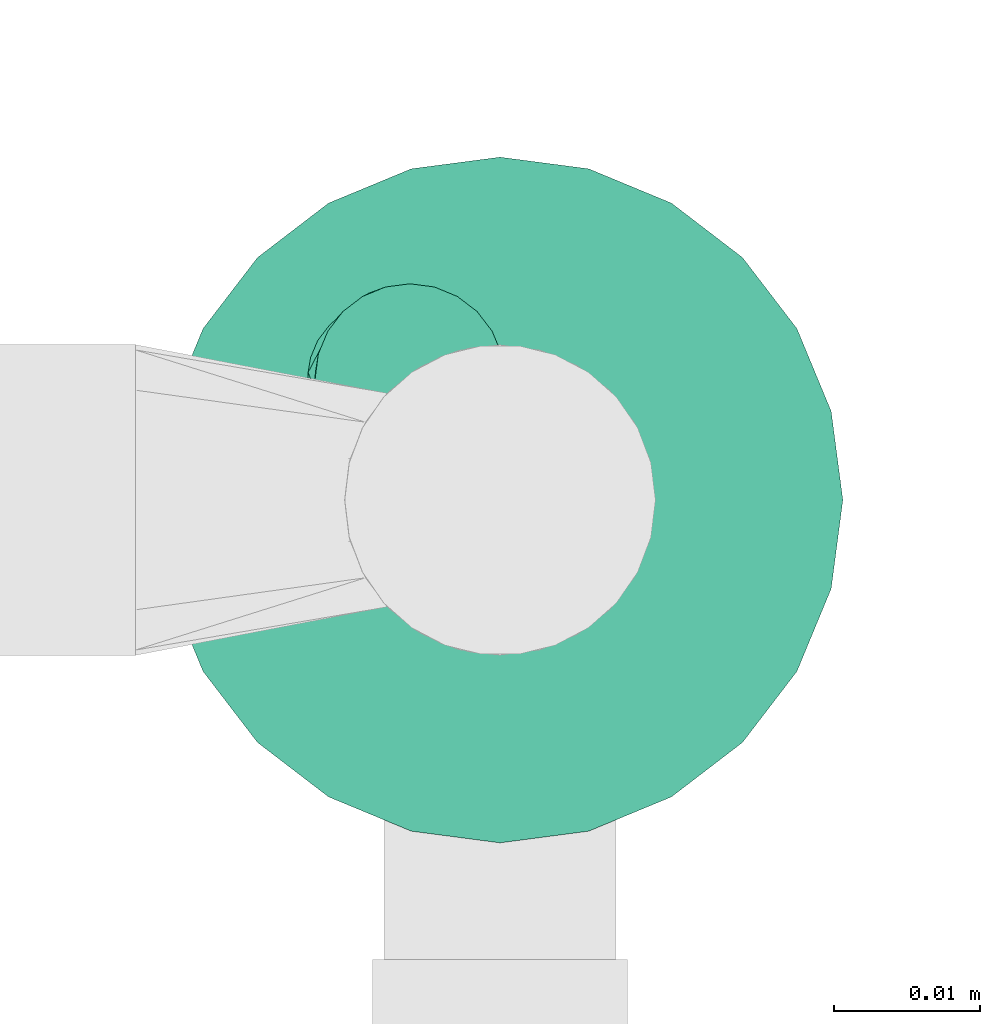
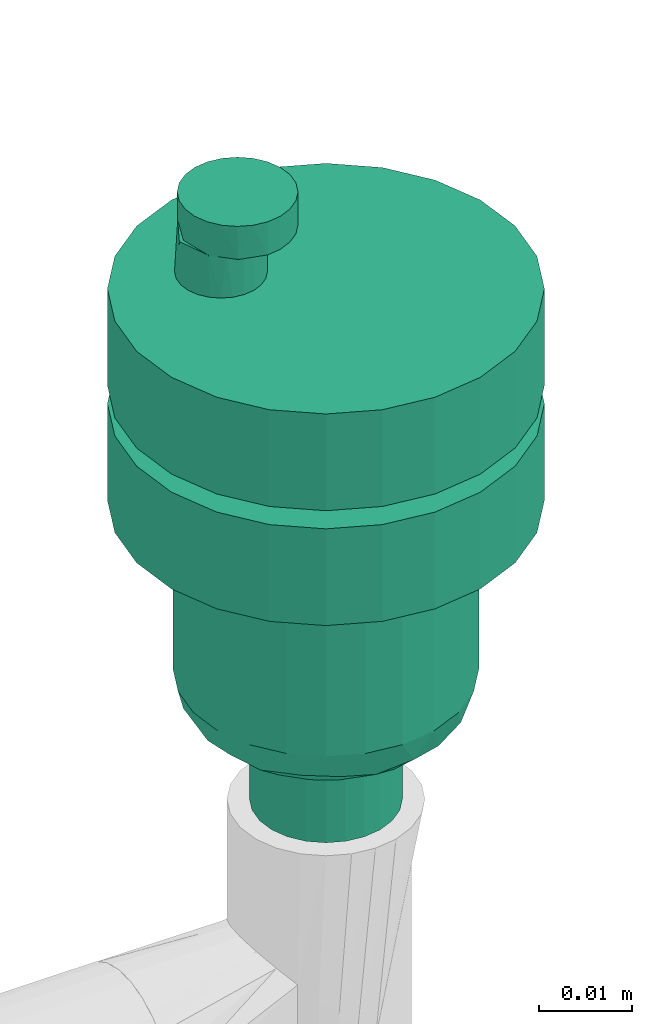
# One storey, part 791 of 827: 1 flow controller.
"""IFC2X3 building model written with IfcOpenShell, lengths in millimetres."""

from ifc_helpers import new_model, entity, si_unit, converted_unit, derived_unit, direction, frame, origin, place, context, subcontext, project, spatial, faceted_brep, source, transform, mapped, material, type_object, type_shapes, element, save


model = new_model("IFC2X3")

# Units and contexts
model_context = context("Model", 3, precision=0.01, world=origin(), true_north=direction((6.12303176911189e-17, 1.0)))
body_context = subcontext(model_context, "Body", "Model", "MODEL_VIEW")
ifc_project = project(units=[si_unit("LENGTHUNIT", "METRE", prefix="MILLI"), si_unit("AREAUNIT", "SQUARE_METRE"), si_unit("VOLUMEUNIT", "CUBIC_METRE"), converted_unit("PLANEANGLEUNIT", "DEGREE", entity("IfcRatioMeasure", 0.0174532925199433), si_unit("PLANEANGLEUNIT", "RADIAN"), dimensions=[0, 0, 0, 0, 0, 0, 0]), si_unit("MASSUNIT", "GRAM", prefix="KILO"), derived_unit("MASSDENSITYUNIT", [(si_unit("MASSUNIT", "GRAM", prefix="KILO"), 1), (si_unit("LENGTHUNIT", "METRE"), -3)]), derived_unit("MOMENTOFINERTIAUNIT", [(si_unit("LENGTHUNIT", "METRE"), 4)]), si_unit("TIMEUNIT", "SECOND"), si_unit("FREQUENCYUNIT", "HERTZ"), si_unit("THERMODYNAMICTEMPERATUREUNIT", "DEGREE_CELSIUS"), derived_unit("THERMALTRANSMITTANCEUNIT", [(si_unit("MASSUNIT", "GRAM", prefix="KILO"), 1), (si_unit("THERMODYNAMICTEMPERATUREUNIT", "KELVIN"), -1), (si_unit("TIMEUNIT", "SECOND"), -3)]), derived_unit("VOLUMETRICFLOWRATEUNIT", [(si_unit("LENGTHUNIT", "METRE"), 3), (si_unit("TIMEUNIT", "SECOND"), -1)]), derived_unit("MASSFLOWRATEUNIT", [(si_unit("MASSUNIT", "GRAM", prefix="KILO"), 1), (si_unit("TIMEUNIT", "SECOND"), -1)]), derived_unit("ROTATIONALFREQUENCYUNIT", [(si_unit("TIMEUNIT", "SECOND"), -1)]), si_unit("ELECTRICCURRENTUNIT", "AMPERE"), si_unit("ELECTRICVOLTAGEUNIT", "VOLT"), si_unit("POWERUNIT", "WATT"), si_unit("FORCEUNIT", "NEWTON", prefix="KILO"), si_unit("ILLUMINANCEUNIT", "LUX"), si_unit("LUMINOUSFLUXUNIT", "LUMEN"), si_unit("LUMINOUSINTENSITYUNIT", "CANDELA"), derived_unit("USERDEFINED", [(si_unit("MASSUNIT", "GRAM", prefix="KILO"), -1), (si_unit("LENGTHUNIT", "METRE"), -2), (si_unit("TIMEUNIT", "SECOND"), 3), (si_unit("LUMINOUSFLUXUNIT", "LUMEN"), 1)]), derived_unit("LINEARVELOCITYUNIT", [(si_unit("LENGTHUNIT", "METRE"), 1), (si_unit("TIMEUNIT", "SECOND"), -1)]), si_unit("PRESSUREUNIT", "PASCAL"), derived_unit("USERDEFINED", [(si_unit("LENGTHUNIT", "METRE"), -2), (si_unit("MASSUNIT", "GRAM", prefix="KILO"), 1), (si_unit("TIMEUNIT", "SECOND"), -2)]), derived_unit("LINEARFORCEUNIT", [(si_unit("MASSUNIT", "GRAM", prefix="KILO"), 1), (si_unit("LENGTHUNIT", "METRE"), 1), (si_unit("TIMEUNIT", "SECOND"), -2), (si_unit("LENGTHUNIT", "METRE"), -1)]), derived_unit("PLANARFORCEUNIT", [(si_unit("MASSUNIT", "GRAM", prefix="KILO"), 1), (si_unit("LENGTHUNIT", "METRE"), 1), (si_unit("TIMEUNIT", "SECOND"), -2), (si_unit("LENGTHUNIT", "METRE"), -2)])], contexts=[model_context])

# Site, building, storey
site_placement = place(None, origin())
site = spatial("IfcSite", under=ifc_project, at=site_placement, CompositionType="ELEMENT")
building_placement = place(site_placement, origin())
building = spatial("IfcBuilding", under=site, at=building_placement, CompositionType="ELEMENT")
storey_placement = place(building_placement, frame((0.0, 0.0, 28200.0)))
storey = spatial("IfcBuildingStorey", under=building, at=storey_placement, Name="08", CompositionType="ELEMENT", Elevation=28200.0)

# Flow controller
ifc_material = material()
valve_type = type_object("IfcValveType", PredefinedType="NOTDEFINED", material=ifc_material)
shared_shape = source(origin(), body_context, "Body", "Brep", [
    faceted_brep([(-11.72, 4.93, 2.49), (-11.69, 4.91, -3.0), (-10.66, 4.11, -3.0), (-13.15, 8.75, 2.49), (-12.99, 7.15, -3.0), (-12.49, 5.94, -3.0), (-9.45, 3.61, -3.0), (-8.16, 3.44, -3.0), (-8.16, 3.44, 2.49), (-9.45, 3.61, -15.7), (-9.45, 3.61, -18.08), (-8.16, 3.44, -18.08), (-8.16, 3.44, -15.7), (-10.09, 3.83, 2.49), (-13.16, 8.44, -3.0), (-11.27, 12.36, 2.49), (-11.69, 11.98, -3.0), (-12.49, 10.94, -3.0), (-8.16, 13.44, 2.49), (-8.16, 13.44, -3.0), (-9.45, 13.27, -3.0), (-8.16, 13.44, -15.7), (-8.16, 13.44, -18.08), (-9.45, 13.27, -18.08), (-9.45, 13.27, -15.7), (-9.8, 13.16, 2.49), (-10.66, 12.77, -3.0), (-12.99, 9.74, -3.0), (-5.66, 12.77, -15.7), (-5.66, 12.77, -18.08), (-6.86, 13.27, -18.08), (-6.86, 13.27, -15.7), (-5.66, 12.77, 2.49), (-5.66, 12.77, -3.0), (-6.86, 13.27, -3.0), (-6.86, 13.27, 2.49), (-3.33, 9.74, -15.7), (-3.33, 9.74, -18.08), (-3.83, 10.94, -18.08), (-3.83, 10.94, -15.7), (-3.33, 9.74, 2.49), (-3.33, 9.74, -3.0), (-3.83, 10.94, -3.0), (-3.83, 10.94, 2.49), (-4.62, 11.98, -18.08), (-4.62, 11.98, -15.7), (-4.62, 11.98, -3.0), (-4.62, 11.98, 2.49), (-3.16, 8.44, -15.7), (-3.16, 8.44, -18.08), (-3.16, 8.44, 2.49), (-3.16, 8.44, -3.0), (-4.62, 4.91, -15.7), (-4.62, 4.91, -18.08), (-3.83, 5.94, -18.08), (-3.83, 5.94, -15.7), (-4.62, 4.91, 2.49), (-4.62, 4.91, -3.0), (-3.83, 5.94, -3.0), (-3.83, 5.94, 2.49), (-3.33, 7.15, -18.08), (-3.33, 7.15, -15.7), (-3.33, 7.15, -3.0), (-3.33, 7.15, 2.49), (-6.86, 3.61, -18.08), (-6.86, 3.61, -15.7), (-6.86, 3.61, -3.0), (-6.86, 3.61, 2.49), (-5.66, 4.11, -18.08), (-5.66, 4.11, -15.7), (-5.66, 4.11, -3.0), (-5.66, 4.11, 2.49), (-12.66, 8.72, 2.49), (-10.66, 4.11, -15.7), (-10.66, 4.11, -18.08), (-12.99, 7.15, -15.7), (-12.99, 7.15, -18.08), (-12.49, 5.94, -18.08), (-12.49, 5.94, -15.7), (-11.69, 4.91, -18.08), (-11.69, 4.91, -15.7), (-13.16, 8.44, -15.7), (-13.16, 8.44, -18.08), (-11.69, 11.98, -15.7), (-11.69, 11.98, -18.08), (-12.49, 10.94, -18.08), (-12.49, 10.94, -15.7), (-12.99, 9.74, -18.08), (-12.99, 9.74, -15.7), (-10.66, 12.77, -18.08), (-10.66, 12.77, -15.7), (0.0, 23.5, -3.0), (6.08, 22.7, -3.0), (-6.08, 22.7, -3.0), (-11.75, 20.35, -3.0), (-16.62, 16.62, -3.0), (-20.35, 11.75, -3.0), (-22.7, 6.08, -3.0), (-23.5, 0.0, -3.0), (-22.7, -6.08, -3.0), (-20.35, -11.75, -3.0), (-16.62, -16.62, -3.0), (-11.75, -20.35, -3.0), (-6.08, -22.7, -3.0), (0.0, -23.5, -3.0), (6.08, -22.7, -3.0), (11.75, -20.35, -3.0), (16.62, -16.62, -3.0), (20.35, -11.75, -3.0), (22.7, -6.08, -3.0), (23.5, 0.0, -3.0), (22.7, 6.08, -3.0), (20.35, 11.75, -3.0), (16.62, 16.62, -3.0), (11.75, 20.35, -3.0), (6.08, -22.7, -15.7), (11.75, -20.35, -15.7), (0.0, -23.5, -15.7), (-6.08, -22.7, -15.7), (-11.75, -20.35, -15.7), (-16.62, -16.62, -15.7), (-20.35, -11.75, -15.7), (-22.7, -6.08, -15.7), (-23.5, 0.0, -15.7), (-22.7, 6.08, -15.7), (-20.35, 11.75, -15.7), (-16.62, 16.62, -15.7), (-11.75, 20.35, -15.7), (-6.08, 22.7, -15.7), (0.0, 23.5, -15.7), (6.08, 22.7, -15.7), (11.75, 20.35, -15.7), (16.62, 16.62, -15.7), (20.35, 11.75, -15.7), (22.7, 6.08, -15.7), (23.5, 0.0, -15.7), (22.7, -6.08, -15.7), (20.35, -11.75, -15.7), (16.62, -16.62, -15.7), (-23.5, 0.0, -30.78), (-23.5, 0.0, -18.08), (-22.7, 6.08, -18.08), (-22.7, 6.08, -30.78), (-20.35, 11.75, -18.08), (-20.35, 11.75, -30.78), (-11.75, 20.35, -30.78), (-16.62, 16.62, -30.78), (-16.62, 16.62, -18.08), (-11.75, 20.35, -18.08), (-6.08, 22.7, -30.78), (-6.08, 22.7, -18.08), (0.0, 23.5, -18.08), (0.0, 23.5, -30.78), (6.08, 22.7, -18.08), (6.08, 22.7, -30.78), (11.75, 20.35, -18.08), (11.75, 20.35, -30.78), (20.35, 11.75, -30.78), (16.62, 16.62, -30.78), (16.62, 16.62, -18.08), (20.35, 11.75, -18.08), (22.7, 6.08, -30.78), (22.7, 6.08, -18.08), (23.5, 0.0, -18.08), (23.5, 0.0, -30.78), (22.7, -6.08, -18.08), (22.7, -6.08, -30.78), (20.35, -11.75, -18.08), (20.35, -11.75, -30.78), (11.75, -20.35, -30.78), (16.62, -16.62, -30.78), (16.62, -16.62, -18.08), (11.75, -20.35, -18.08), (6.08, -22.7, -30.78), (6.08, -22.7, -18.08), (0.0, -23.5, -18.08), (0.0, -23.5, -30.78), (-6.08, -22.7, -18.08), (-6.08, -22.7, -30.78), (-11.75, -20.35, -18.08), (-11.75, -20.35, -30.78), (-20.35, -11.75, -30.78), (-16.62, -16.62, -30.78), (-16.62, -16.62, -18.08), (-20.35, -11.75, -18.08), (-22.7, -6.08, -30.78), (-22.7, -6.08, -18.08), (8.23, -14.25, -30.78), (11.63, -11.63, -30.78), (4.26, -15.89, -30.78), (14.25, -8.22, -30.78), (15.89, -4.26, -30.78), (16.45, 0.0, -30.78), (15.89, 4.26, -30.78), (14.25, 8.23, -30.78), (11.63, 11.63, -30.78), (8.23, 14.25, -30.78), (4.26, 15.89, -30.78), (0.0, 16.45, -30.78), (-4.26, 15.89, -30.78), (-8.22, 14.25, -30.78), (-11.63, 11.63, -30.78), (-14.25, 8.23, -30.78), (-15.89, 4.26, -30.78), (-16.45, 0.0, -30.78), (-15.89, -4.26, -30.78), (-14.25, -8.22, -30.78), (-11.63, -11.63, -30.78), (-8.22, -14.25, -30.78), (-4.26, -15.89, -30.78), (0.0, -16.45, -30.78), (-16.45, 0.0, -52.9), (-15.89, 4.26, -52.9), (-14.25, 8.23, -52.9), (-8.22, 14.25, -52.9), (-11.63, 11.63, -52.9), (-4.26, 15.89, -52.9), (0.0, 16.45, -52.9), (4.26, 15.89, -52.9), (15.89, 4.26, -52.9), (14.25, 8.23, -52.9), (11.63, 11.63, -52.9), (16.45, 0.0, -52.9), (8.23, 14.25, -52.9), (15.89, -4.26, -52.9), (14.25, -8.22, -52.9), (8.23, -14.25, -52.9), (11.63, -11.63, -52.9), (4.26, -15.89, -52.9), (0.0, -16.45, -52.9), (-11.63, -11.63, -52.9), (-8.22, -14.25, -52.9), (-15.89, -4.26, -52.9), (-14.25, -8.22, -52.9), (-4.26, -15.89, -52.9), (14.82, -4.97, -55.95), (12.59, -7.71, -57.11), (12.51, 0.0, -58.11), (-6.3, -14.03, -56.35), (-9.96, -11.84, -56.21), (-8.07, -10.51, -58.27), (6.26, -13.38, -57.1), (2.16, -15.25, -56.32), (-2.15, -14.51, -57.21), (9.95, -11.76, -56.32), (3.55, -12.65, -58.32), (14.66, 0.0, -57.21), (-14.82, -4.97, -55.95), (-12.51, 0.0, -58.11), (-12.59, -7.71, -57.11), (10.47, -8.07, -58.28), (8.05, -10.02, -58.46), (7.76, -4.48, -59.0), (-10.51, -8.04, -58.28), (-11.63, -4.89, -58.56), (9.06, -2.24, -59.0), (-14.66, 0.0, -57.21), (2.59, -8.96, -59.0), (5.18, -8.96, -59.0), (5.88, -11.19, -58.56), (-5.32, -12.14, -58.27), (-2.59, -8.96, -59.0), (0.59, -13.61, -58.05), (-6.47, -6.72, -59.0), (10.35, 0.0, -59.0), (11.43, 0.0, -58.55), (11.93, -4.48, -58.51), (-7.76, -4.48, -59.0), (-10.35, 0.0, -59.0), (-9.06, -2.24, -59.0), (-5.17, -8.96, -59.0), (0.0, -8.96, -59.0), (-11.43, 0.0, -58.55), (6.47, -6.72, -59.0), (-14.82, 4.97, -55.95), (-12.59, 7.71, -57.11), (6.3, 14.03, -56.35), (9.96, 11.84, -56.21), (8.07, 10.51, -58.27), (-6.26, 13.38, -57.1), (-2.16, 15.25, -56.32), (2.15, 14.51, -57.21), (-9.95, 11.76, -56.32), (-10.47, 8.07, -58.28), (-8.05, 10.02, -58.46), (-5.88, 11.19, -58.56), (-3.55, 12.65, -58.32), (-5.17, 8.96, -59.0), (5.32, 12.14, -58.27), (2.59, 8.96, -59.0), (12.59, 7.71, -57.11), (10.51, 8.04, -58.28), (-7.76, 4.48, -59.0), (-9.06, 2.24, -59.0), (14.82, 4.97, -55.95), (6.47, 6.72, -59.0), (-2.59, 8.96, -59.0), (11.63, 4.89, -58.56), (-0.59, 13.61, -58.05), (-11.93, 4.48, -58.51), (7.76, 4.48, -59.0), (9.06, 2.24, -59.0), (5.18, 8.96, -59.0), (0.0, 8.96, -59.0), (-6.47, 6.72, -59.0), (-8.22, 0.0, -59.0), (-7.94, -2.13, -59.0), (-7.12, -4.11, -59.0), (-7.94, 2.13, -59.0), (-7.12, 4.11, -59.0), (-5.82, 5.82, -59.0), (-4.11, 7.12, -59.0), (-2.13, 7.94, -59.0), (0.0, 8.23, -59.0), (2.13, 7.94, -59.0), (4.11, 7.12, -59.0), (5.82, 5.82, -59.0), (7.12, 4.11, -59.0), (7.94, 2.13, -59.0), (8.23, 0.0, -59.0), (7.94, -2.13, -59.0), (7.12, -4.11, -59.0), (5.82, -5.82, -59.0), (4.11, -7.12, -59.0), (2.13, -7.94, -59.0), (0.0, -8.22, -59.0), (-5.82, -5.82, -59.0), (-4.11, -7.12, -59.0), (-2.13, -7.94, -59.0), (4.11, -7.12, -70.0), (2.13, -7.94, -70.0), (0.0, -8.22, -70.0), (-2.13, -7.94, -70.0), (-4.11, -7.12, -70.0), (-5.82, -5.82, -70.0), (-7.12, -4.11, -70.0), (-7.94, -2.13, -70.0), (-8.22, 0.0, -70.0), (-7.94, 2.13, -70.0), (-7.12, 4.11, -70.0), (-5.82, 5.82, -70.0), (-4.11, 7.12, -70.0), (-2.13, 7.94, -70.0), (0.0, 8.23, -70.0), (2.13, 7.94, -70.0), (4.11, 7.12, -70.0), (5.82, 5.82, -70.0), (7.12, 4.11, -70.0), (7.94, 2.13, -70.0), (8.23, 0.0, -70.0), (7.94, -2.13, -70.0), (7.12, -4.11, -70.0), (5.82, -5.82, -70.0), (-0.54, 5.07, 6.83), (0.11, 6.64, 6.83), (0.33, 8.32, 6.83), (0.11, 10.01, 6.83), (-0.54, 11.57, 6.83), (-1.57, 12.92, 6.83), (-2.92, 13.95, 6.83), (-4.49, 14.6, 6.83), (-6.17, 14.82, 6.83), (-7.85, 14.6, 6.83), (-9.42, 13.95, 6.83), (-10.77, 12.92, 6.83), (-11.8, 11.57, 6.83), (-12.45, 10.01, 6.83), (-12.67, 8.32, 6.83), (-12.45, 6.64, 6.83), (-11.8, 5.07, 6.83), (-10.77, 3.73, 6.83), (-9.42, 2.7, 6.83), (-7.85, 2.05, 6.83), (-6.17, 1.82, 6.83), (-4.49, 2.05, 6.83), (-2.92, 2.7, 6.83), (-1.57, 3.73, 6.83), (-9.0, 14.17, 2.49), (-6.17, 14.82, 2.49), (-4.49, 14.6, 2.49), (-2.92, 13.95, 2.49), (-1.57, 12.92, 2.49), (-0.54, 11.57, 2.49), (0.11, 10.01, 2.49), (0.33, 8.32, 2.49), (0.11, 6.64, 2.49), (-0.54, 5.07, 2.49), (-1.57, 3.73, 2.49), (-2.92, 2.7, 2.49), (-4.49, 2.05, 2.49), (-6.17, 1.82, 2.49), (-9.35, 2.65, 2.49)], [[[0, 1, 2]], [[3, 4, 0]], [[0, 4, 5]], [[0, 5, 1]], [[6, 7, 8]], [[9, 10, 11, 12]], [[6, 13, 2]], [[0, 2, 13]], [[8, 13, 6]], [[3, 14, 4]], [[15, 16, 17]], [[18, 19, 20]], [[21, 22, 23, 24]], [[25, 20, 26]], [[15, 26, 16]], [[3, 17, 27]], [[14, 3, 27]], [[17, 3, 15]], [[15, 25, 26]], [[25, 18, 20]], [[28, 29, 30, 31]], [[32, 33, 34, 35]], [[31, 30, 22, 21]], [[35, 34, 19, 18]], [[36, 37, 38, 39]], [[40, 41, 42, 43]], [[39, 38, 44, 45]], [[43, 42, 46, 47]], [[45, 44, 29, 28]], [[47, 46, 33, 32]], [[37, 36, 48, 49]], [[41, 40, 50, 51]], [[52, 53, 54, 55]], [[56, 57, 58, 59]], [[55, 54, 60, 61]], [[59, 58, 62, 63]], [[12, 11, 64, 65]], [[8, 7, 66, 67]], [[65, 64, 68, 69]], [[67, 66, 70, 71]], [[69, 68, 53, 52]], [[71, 70, 57, 56]], [[49, 48, 61, 60]], [[51, 50, 63, 62]], [[15, 3, 0, 72]], [[73, 74, 10, 9]], [[75, 76, 77, 78]], [[78, 77, 79, 80]], [[80, 79, 74, 73]], [[76, 75, 81, 82]], [[83, 84, 85, 86]], [[86, 85, 87, 88]], [[24, 23, 89, 90]], [[90, 89, 84, 83]], [[82, 81, 88, 87]], [[91, 42, 92]], [[42, 91, 46]], [[91, 33, 46]], [[93, 33, 91]], [[34, 33, 93]], [[34, 93, 19]], [[93, 94, 19]], [[94, 20, 19]], [[20, 94, 26]], [[95, 26, 94]], [[16, 26, 95]], [[16, 95, 17]], [[95, 96, 17]], [[17, 96, 27]], [[14, 27, 96]], [[14, 96, 97]], [[97, 4, 14]], [[5, 4, 97]], [[5, 97, 98]], [[5, 98, 1]], [[2, 1, 98]], [[2, 98, 99]], [[99, 6, 2]], [[99, 100, 6]], [[100, 7, 6]], [[100, 101, 7]], [[101, 102, 7]], [[66, 7, 102]], [[102, 103, 66]], [[103, 104, 66]], [[70, 66, 104]], [[104, 105, 70]], [[105, 106, 70]], [[57, 70, 106]], [[57, 106, 107]], [[57, 107, 108]], [[58, 57, 108]], [[109, 58, 108]], [[109, 110, 58]], [[58, 110, 62]], [[110, 111, 62]], [[111, 112, 62]], [[51, 62, 112]], [[113, 51, 112]], [[51, 113, 114]], [[92, 41, 114]], [[114, 41, 51]], [[41, 92, 42]], [[115, 69, 116]], [[117, 69, 115]], [[69, 117, 65]], [[117, 118, 65]], [[65, 118, 119]], [[65, 119, 12]], [[120, 12, 119]], [[121, 12, 120]], [[12, 121, 9]], [[122, 9, 121]], [[9, 122, 73]], [[73, 122, 123]], [[73, 123, 80]], [[78, 80, 123]], [[123, 124, 78]], [[78, 124, 75]], [[75, 124, 81]], [[81, 124, 125]], [[125, 88, 81]], [[86, 88, 125]], [[126, 86, 125]], [[126, 83, 86]], [[83, 126, 90]], [[126, 127, 90]], [[24, 90, 127]], [[127, 21, 24]], [[21, 127, 128]], [[21, 128, 31]], [[31, 128, 28]], [[128, 129, 28]], [[129, 45, 28]], [[39, 45, 129]], [[39, 129, 130]], [[36, 39, 130]], [[36, 130, 131]], [[131, 48, 36]], [[132, 48, 131]], [[48, 132, 133]], [[48, 133, 61]], [[134, 61, 133]], [[134, 135, 61]], [[135, 55, 61]], [[135, 136, 55]], [[55, 136, 137]], [[55, 137, 52]], [[52, 137, 138]], [[116, 52, 138]], [[52, 116, 69]], [[123, 98, 97, 124]], [[139, 140, 141, 142]], [[124, 97, 96, 125]], [[142, 141, 143, 144]], [[127, 126, 95, 94]], [[145, 146, 147, 148]], [[95, 126, 125, 96]], [[147, 146, 144, 143]], [[128, 127, 94, 93]], [[149, 145, 148, 150]], [[128, 93, 91, 129]], [[149, 150, 151, 152]], [[129, 91, 92, 130]], [[152, 151, 153, 154]], [[130, 92, 114, 131]], [[154, 153, 155, 156]], [[133, 132, 113, 112]], [[157, 158, 159, 160]], [[113, 132, 131, 114]], [[159, 158, 156, 155]], [[134, 133, 112, 111]], [[161, 157, 160, 162]], [[134, 111, 110, 135]], [[161, 162, 163, 164]], [[135, 110, 109, 136]], [[164, 163, 165, 166]], [[136, 109, 108, 137]], [[166, 165, 167, 168]], [[116, 138, 107, 106]], [[169, 170, 171, 172]], [[107, 138, 137, 108]], [[171, 170, 168, 167]], [[115, 116, 106, 105]], [[173, 169, 172, 174]], [[115, 105, 104, 117]], [[173, 174, 175, 176]], [[117, 104, 103, 118]], [[176, 175, 177, 178]], [[118, 103, 102, 119]], [[178, 177, 179, 180]], [[121, 120, 101, 100]], [[181, 182, 183, 184]], [[101, 120, 119, 102]], [[183, 182, 180, 179]], [[122, 121, 100, 99]], [[185, 181, 184, 186]], [[122, 99, 98, 123]], [[185, 186, 140, 139]], [[151, 38, 153]], [[38, 151, 44]], [[151, 29, 44]], [[150, 29, 151]], [[30, 29, 150]], [[30, 150, 22]], [[150, 148, 22]], [[148, 23, 22]], [[23, 148, 89]], [[147, 89, 148]], [[84, 89, 147]], [[84, 147, 85]], [[147, 143, 85]], [[85, 143, 87]], [[82, 87, 143]], [[82, 143, 141]], [[141, 76, 82]], [[77, 76, 141]], [[77, 141, 140]], [[77, 140, 79]], [[74, 79, 140]], [[74, 140, 186]], [[186, 10, 74]], [[186, 184, 10]], [[184, 11, 10]], [[184, 183, 11]], [[183, 179, 11]], [[64, 11, 179]], [[179, 177, 64]], [[177, 175, 64]], [[68, 64, 175]], [[175, 174, 68]], [[174, 172, 68]], [[53, 68, 172]], [[53, 172, 171]], [[53, 171, 167]], [[54, 53, 167]], [[165, 54, 167]], [[165, 163, 54]], [[54, 163, 60]], [[163, 162, 60]], [[162, 160, 60]], [[49, 60, 160]], [[159, 49, 160]], [[49, 159, 155]], [[153, 37, 155]], [[155, 37, 49]], [[37, 153, 38]], [[187, 170, 169]], [[188, 170, 187]], [[189, 187, 169]], [[170, 188, 168]], [[168, 188, 190]], [[168, 190, 191]], [[166, 168, 191]], [[192, 166, 191]], [[164, 166, 192]], [[164, 192, 193]], [[161, 164, 193]], [[161, 193, 194]], [[157, 161, 194]], [[157, 194, 195]], [[195, 158, 157]], [[195, 196, 158]], [[156, 158, 196]], [[197, 156, 196]], [[156, 197, 154]], [[198, 154, 197]], [[152, 154, 198]], [[198, 199, 152]], [[149, 152, 199]], [[200, 149, 199]], [[149, 200, 145]], [[200, 201, 145]], [[201, 146, 145]], [[146, 201, 202]], [[146, 202, 144]], [[144, 202, 142]], [[142, 202, 203]], [[139, 142, 203]], [[203, 204, 139]], [[139, 204, 185]], [[204, 205, 185]], [[181, 185, 205]], [[181, 205, 206]], [[182, 181, 206]], [[207, 182, 206]], [[207, 180, 182]], [[208, 180, 207]], [[178, 180, 208]], [[208, 209, 178]], [[178, 209, 176]], [[210, 176, 209]], [[210, 189, 173]], [[176, 210, 173]], [[169, 173, 189]], [[211, 204, 203, 212]], [[212, 203, 202, 213]], [[214, 215, 201, 200]], [[201, 215, 213, 202]], [[216, 214, 200, 199]], [[216, 199, 198, 217]], [[197, 218, 217, 198]], [[219, 220, 194, 193]], [[221, 195, 194, 220]], [[222, 219, 193, 192]], [[197, 196, 223, 218]], [[195, 221, 223, 196]], [[222, 192, 191, 224]], [[224, 191, 190, 225]], [[226, 227, 188, 187]], [[188, 227, 225, 190]], [[228, 226, 187, 189]], [[228, 189, 210, 229]], [[230, 231, 208, 207]], [[232, 233, 206, 205]], [[207, 206, 233, 230]], [[232, 205, 204, 211]], [[234, 209, 208, 231]], [[234, 229, 210, 209]], [[235, 236, 237]], [[238, 239, 240]], [[234, 231, 238]], [[241, 226, 228]], [[242, 229, 243]], [[244, 226, 241]], [[241, 242, 245]], [[224, 246, 222]], [[230, 239, 231]], [[235, 246, 224]], [[239, 238, 231]], [[247, 248, 249]], [[250, 244, 251]], [[226, 244, 227]], [[252, 250, 251]], [[239, 230, 249]], [[253, 249, 254]], [[234, 238, 243]], [[233, 249, 230]], [[240, 239, 253]], [[250, 252, 255]], [[247, 232, 256]], [[257, 258, 245]], [[225, 227, 236]], [[228, 229, 242]], [[229, 234, 243]], [[247, 233, 232]], [[211, 256, 232]], [[224, 225, 235]], [[241, 228, 242]], [[259, 245, 258]], [[260, 261, 243]], [[244, 236, 227]], [[245, 242, 262]], [[251, 241, 259]], [[240, 263, 260]], [[264, 265, 237, 266]], [[235, 225, 236]], [[237, 246, 235]], [[247, 249, 233]], [[260, 238, 240]], [[248, 254, 249]], [[247, 256, 248]], [[267, 240, 253]], [[254, 268, 269]], [[249, 253, 239]], [[260, 243, 238]], [[270, 261, 260]], [[271, 257, 262, 261]], [[262, 243, 261]], [[243, 262, 242]], [[257, 245, 262]], [[269, 267, 253]], [[253, 254, 269]], [[254, 248, 272, 268]], [[237, 236, 266]], [[250, 236, 244]], [[273, 252, 251]], [[241, 251, 244]], [[266, 250, 255]], [[264, 266, 255]], [[266, 236, 250]], [[270, 260, 263]], [[240, 267, 263]], [[245, 259, 241]], [[258, 273, 259]], [[251, 259, 273]], [[274, 275, 248]], [[276, 277, 278]], [[218, 223, 276]], [[279, 214, 216]], [[280, 217, 281]], [[282, 214, 279]], [[213, 215, 275]], [[212, 256, 211]], [[221, 277, 223]], [[274, 256, 212]], [[279, 216, 280]], [[216, 217, 280]], [[283, 282, 284]], [[285, 286, 287]], [[288, 289, 281]], [[277, 221, 290]], [[291, 278, 277]], [[283, 292, 293]], [[222, 246, 219]], [[246, 294, 219]], [[278, 295, 288]], [[296, 287, 286]], [[282, 275, 215]], [[219, 294, 220]], [[292, 283, 284]], [[281, 217, 218]], [[281, 218, 276]], [[297, 291, 290]], [[214, 282, 215]], [[294, 237, 290]], [[221, 220, 290]], [[277, 276, 223]], [[279, 280, 286]], [[286, 280, 298]], [[284, 279, 285]], [[212, 213, 274]], [[268, 272, 248, 299]], [[274, 213, 275]], [[248, 256, 274]], [[294, 290, 220]], [[288, 276, 278]], [[237, 297, 290]], [[294, 246, 237]], [[300, 278, 291]], [[297, 264, 301]], [[290, 291, 277]], [[288, 281, 276]], [[302, 289, 288]], [[303, 296, 298, 289]], [[298, 281, 289]], [[281, 298, 280]], [[296, 286, 298]], [[301, 300, 291]], [[291, 297, 301]], [[297, 237, 265, 264]], [[248, 275, 299]], [[283, 275, 282]], [[304, 292, 284]], [[279, 284, 282]], [[299, 283, 293]], [[268, 299, 293]], [[299, 275, 283]], [[302, 288, 295]], [[278, 300, 295]], [[286, 285, 279]], [[287, 304, 285]], [[284, 285, 304]], [[268, 305, 306]], [[306, 307, 268]], [[305, 268, 308]], [[309, 308, 268]], [[309, 268, 293]], [[307, 269, 268]], [[309, 293, 292]], [[309, 292, 304]], [[309, 304, 287]], [[287, 310, 309]], [[310, 287, 311]], [[312, 311, 287]], [[287, 313, 312]], [[313, 287, 296]], [[313, 296, 303]], [[313, 303, 289]], [[313, 289, 302]], [[314, 313, 302]], [[302, 315, 314]], [[315, 302, 316]], [[316, 302, 317]], [[317, 302, 295]], [[317, 295, 300]], [[317, 300, 301]], [[317, 301, 264]], [[264, 318, 317]], [[318, 264, 319]], [[319, 264, 320]], [[321, 320, 264]], [[321, 264, 255]], [[321, 255, 252]], [[321, 252, 273]], [[321, 273, 258]], [[258, 322, 321]], [[323, 322, 258]], [[323, 258, 324]], [[325, 324, 258]], [[325, 258, 257]], [[325, 257, 271]], [[325, 271, 261]], [[325, 261, 270]], [[307, 270, 263]], [[326, 270, 307]], [[270, 326, 327]], [[327, 328, 270]], [[270, 328, 325]], [[307, 263, 267]], [[307, 267, 269]], [[329, 330, 331, 332, 333, 334, 335, 336, 337, 338, 339, 340, 341, 342, 343, 344, 345, 346, 347, 348, 349, 350, 351, 352]], [[337, 305, 308, 338]], [[338, 308, 309, 339]], [[341, 340, 310, 311]], [[310, 340, 339, 309]], [[342, 341, 311, 312]], [[342, 312, 313, 343]], [[343, 313, 314, 344]], [[344, 314, 315, 345]], [[347, 346, 316, 317]], [[316, 346, 345, 315]], [[348, 347, 317, 318]], [[348, 318, 319, 349]], [[349, 319, 320, 350]], [[350, 320, 321, 351]], [[329, 352, 322, 323]], [[322, 352, 351, 321]], [[330, 329, 323, 324]], [[330, 324, 325, 331]], [[331, 325, 328, 332]], [[332, 328, 327, 333]], [[335, 334, 326, 307]], [[326, 334, 333, 327]], [[336, 335, 307, 306]], [[336, 306, 305, 337]], [[353, 354, 355, 356, 357, 358, 359, 360, 361, 362, 363, 364, 365, 366, 367, 368, 369, 370, 371, 372, 373, 374, 375, 376]], [[13, 8, 67, 71, 56, 59, 63, 50, 40, 43, 47, 32, 35, 18, 25, 15, 377, 378, 379, 380, 381, 382, 383, 384, 385, 386, 387, 388, 389, 390, 391, 0]], [[378, 361, 360, 379]], [[379, 360, 359, 380]], [[382, 381, 358, 357]], [[358, 381, 380, 359]], [[383, 382, 357, 356]], [[383, 356, 355, 384]], [[384, 355, 354, 385]], [[385, 354, 353, 386]], [[388, 387, 376, 375]], [[376, 387, 386, 353]], [[389, 388, 375, 374]], [[389, 374, 373, 390]], [[391, 390, 372]], [[367, 72, 368]], [[0, 368, 72]], [[370, 0, 391]], [[0, 369, 368]], [[372, 390, 373]], [[371, 370, 391]], [[391, 372, 371]], [[369, 0, 370]], [[15, 72, 366]], [[378, 377, 362]], [[364, 377, 15]], [[362, 361, 378]], [[365, 15, 366]], [[364, 363, 377]], [[15, 365, 364]], [[362, 377, 363]], [[367, 366, 72]]]),
])
type_shapes(valve_type, [shared_shape])
flow_controller_placement = place(storey_placement, frame((26355.85, 16041.72, 3225.0)))
element("IfcFlowController", 1, at=flow_controller_placement, inside=storey, type_object=valve_type, material=ifc_material, context=body_context, shape_type="MappedRepresentation", body=[
    mapped(shared_shape, transform((0.0, 0.0, 0.0), scale=1.0)),
])

save(model, "model.ifc")
